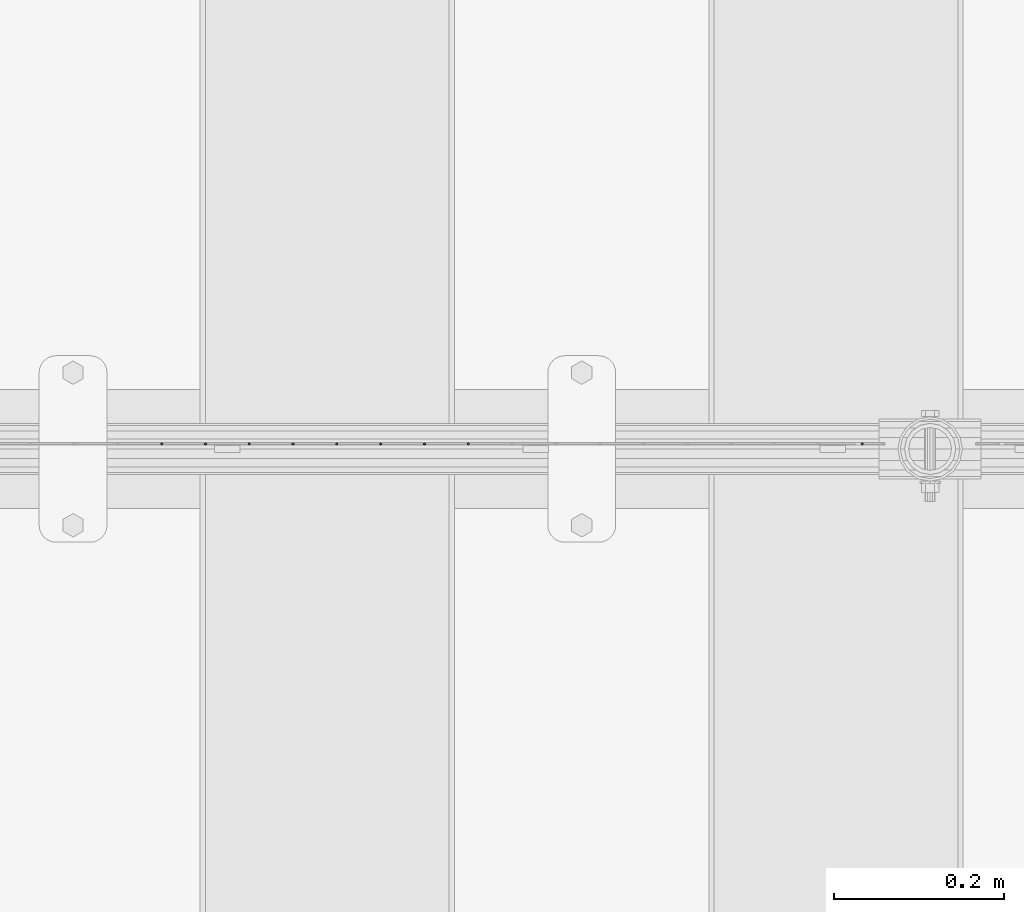
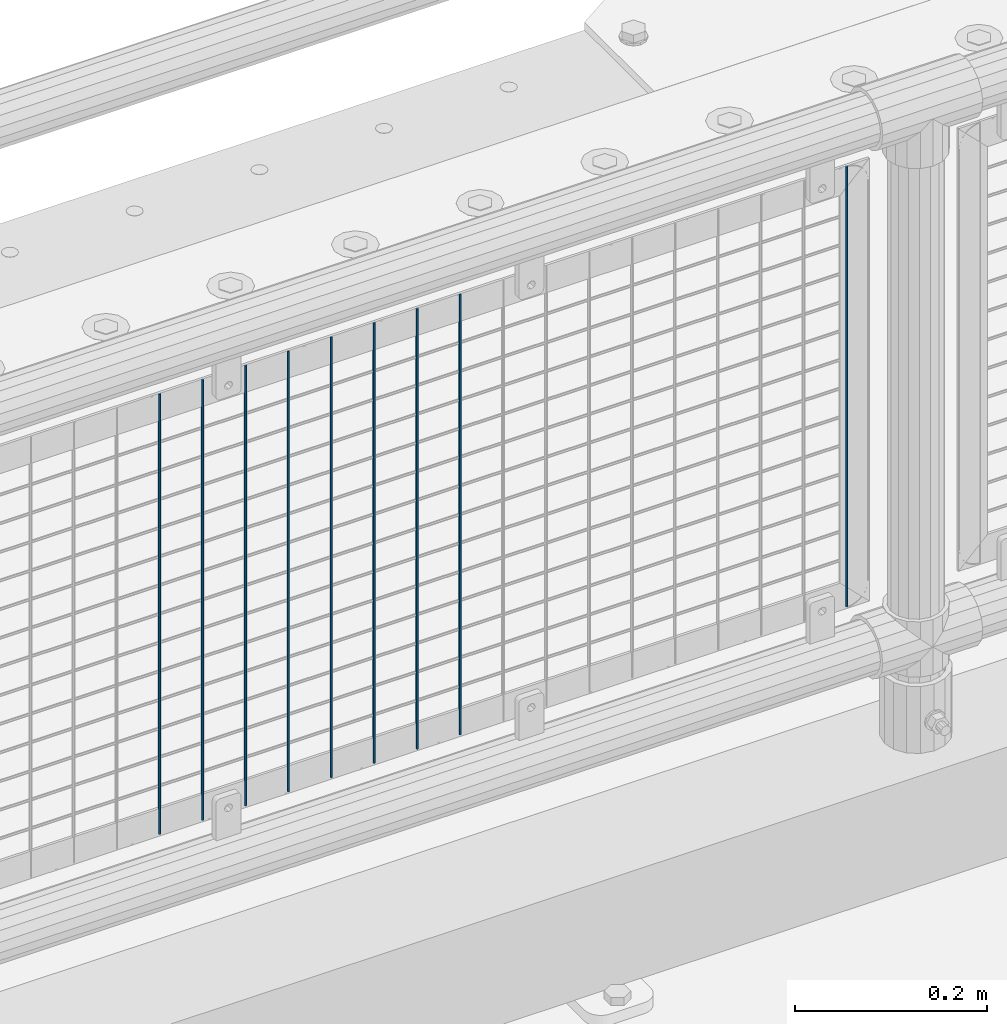
# One storey, part 82 of 219: 9 columns.
"""IFC2X3 building model written with IfcOpenShell, lengths in millimetres."""

import ifcopenshell
import ifcopenshell.guid

model = None  # the IFC model being written
_history = None  # IfcOwnerHistory: only IFC2X3 demands one
_inside = {}  # id of a spatial element -> (the spatial element, [elements in it])
_under = {}  # id of a project, library or spatial element -> (it, [spatial elements below it])
_declared = {}  # id of a project -> (the project, [libraries it declares])
_typed = {}  # id of a type object -> (the type object, [elements of that type])
_made_of = {}  # id of a material, layer set ... -> (it, [elements and type objects made of it])


def new_model(schema):
    """Start an empty IFC model of exactly this schema.

    Asked for "IFC4X3", IfcOpenShell would pick the latest addendum, in which some entities
    have other attributes; the version numbers below select the first issue.
    IFC2X3 requires an IfcOwnerHistory on every rooted entity: one is made here for all.
    """
    global model, _history
    if schema == "IFC4X3":
        model = ifcopenshell.file(schema_version=(4, 3, 0, 0))
    else:
        model = ifcopenshell.file(schema=schema)
    _inside.clear()
    _under.clear()
    _declared.clear()
    _typed.clear()
    _made_of.clear()
    _history = None
    if model.schema == "IFC2X3":
        org = make("IfcOrganization", Name="unknown")
        user = make(
            "IfcPersonAndOrganization",
            ThePerson=make("IfcPerson", FamilyName="unknown"),
            TheOrganization=org,
        )
        app = make(
            "IfcApplication",
            ApplicationDeveloper=org,
            Version="unknown",
            ApplicationFullName="unknown",
            ApplicationIdentifier="unknown",
        )
        _history = make(
            "IfcOwnerHistory",
            OwningUser=user,
            OwningApplication=app,
            ChangeAction="ADDED",
            CreationDate=0,
        )
    return model


def make(cls, **values):
    """One entity of the class cls with the attributes given. An attribute that is None is left unset."""
    return model.create_entity(
        cls, **{name: value for name, value in values.items() if value is not None}
    )


def rooted(cls, **values):
    """An entity with a GlobalId (a new one), such as an element, a storey or a relation."""
    return make(cls, GlobalId=ifcopenshell.guid.new(), OwnerHistory=_history, **values)


def si_unit(unit_type, name, prefix=None):
    """IfcSIUnit, for example si_unit("LENGTHUNIT", "METRE", prefix="MILLI")."""
    return make("IfcSIUnit", UnitType=unit_type, Prefix=prefix, Name=name)


def assignment(units):
    """IfcUnitAssignment: the units of a project."""
    return None if units is None else make("IfcUnitAssignment", Units=units)


def point(xyz):
    """IfcCartesianPoint."""
    return None if xyz is None else make("IfcCartesianPoint", Coordinates=xyz)


def direction(xyz):
    """IfcDirection."""
    return None if xyz is None else make("IfcDirection", DirectionRatios=xyz)


def frame(location, z_axis=None, x_axis=None):
    """IfcAxis2Placement3D, a coordinate frame: its origin and axes. An axis left out is left unset."""
    return make(
        "IfcAxis2Placement3D",
        Location=point(location),
        Axis=direction(z_axis),
        RefDirection=direction(x_axis),
    )


def origin_with_axes():
    """The frame at (0, 0, 0) with the z axis (0, 0, 1) and the x axis (1, 0, 0) written out."""
    return frame((0.0, 0.0, 0.0), z_axis=(0.0, 0.0, 1.0), x_axis=(1.0, 0.0, 0.0))


def place(relative_to, where):
    """IfcLocalPlacement: puts the frame where relative to a parent placement (None: the world)."""
    return make(
        "IfcLocalPlacement", PlacementRelTo=relative_to, RelativePlacement=where
    )


def context(
    kind, dimensions, precision=None, world=None, true_north=None, identifier=None
):
    """IfcGeometricRepresentationContext, for example the 3D "Model" context."""
    return make(
        "IfcGeometricRepresentationContext",
        ContextIdentifier=identifier,
        ContextType=kind,
        CoordinateSpaceDimension=dimensions,
        Precision=precision,
        WorldCoordinateSystem=world,
        TrueNorth=true_north,
    )


def subcontext(parent, identifier, kind, view, scale=None):
    """IfcGeometricRepresentationSubContext, for example "Body" below "Model"."""
    return make(
        "IfcGeometricRepresentationSubContext",
        ContextIdentifier=identifier,
        ContextType=kind,
        ParentContext=parent,
        TargetScale=scale,
        TargetView=view,
    )


def project(units=None, contexts=None):
    """IfcProject with its units and contexts."""
    return rooted(
        "IfcProject",
        Name="project",
        RepresentationContexts=contexts,
        UnitsInContext=assignment(units),
    )


def spatial(cls, under=None, at=None, **own):
    """A site, building, storey or space (cls), placed at a placement, below another one or the project."""
    s = rooted(cls, ObjectPlacement=at, **own)
    if under is not None:
        _under.setdefault(under.id(), (under, []))[1].append(s)
    return s


def faces_of(points, faces, orient=None, outer=None):
    """IfcFace entities. A face is a list of loops; a loop is a list of indices into points, from 0.

    orient and outer hold one flag for each loop. By default every Orientation is true, the
    first loop of a face is its IfcFaceOuterBound and the others are IfcFaceBound.
    """
    made = []
    for i, loops in enumerate(faces):
        bounds = []
        for j, loop in enumerate(loops):
            is_outer = j == 0 if outer is None else outer[i][j]
            bounds.append(
                make(
                    "IfcFaceOuterBound" if is_outer else "IfcFaceBound",
                    Bound=make("IfcPolyLoop", Polygon=[points[k] for k in loop]),
                    Orientation=True if orient is None else orient[i][j],
                )
            )
        made.append(make("IfcFace", Bounds=bounds))
    return made


def faceted_brep(points, faces, orient=None, outer=None, voids=None):
    """IfcFacetedBrep: a solid bounded by flat faces; with voids (closed shells), ...WithVoids."""
    shared = [point(p) for p in points]
    hull = make("IfcClosedShell", CfsFaces=faces_of(shared, faces, orient, outer))
    if voids is None:
        return make("IfcFacetedBrep", Outer=hull)
    return make(
        "IfcFacetedBrepWithVoids",
        Outer=hull,
        Voids=[
            make(cls, CfsFaces=faces_of(shared, fs, o, b)) for cls, fs, o, b in voids
        ],
    )


def shape(context_of_items, identifier, shape_type, items):
    """IfcShapeRepresentation: the items that make up one representation, for example the "Body"."""
    return make(
        "IfcShapeRepresentation",
        ContextOfItems=context_of_items,
        RepresentationIdentifier=identifier,
        RepresentationType=shape_type,
        Items=items,
    )


def material(Name=None, Category=None):
    """IfcMaterial."""
    return make("IfcMaterial", Name=Name, Category=Category)


def made_of(thing, what):
    """Note that an element or type object is made of a material, layer set ...; save() writes the relation."""
    if what is not None:
        _made_of.setdefault(what.id(), (what, []))[1].append(thing)
    return thing


def type_object(cls, material=None, **own):
    """A type object (cls), such as IfcWallType, which elements share."""
    return made_of(rooted(cls, **own), material)


def element(
    cls,
    number,
    at=None,
    inside=None,
    cuts=None,
    type_object=None,
    material=None,
    context=None,
    identifier="Body",
    shape_type=None,
    held_by="IfcProductDefinitionShape",
    body=None,
    shapes=None,
    **own,
):
    """One element of the class cls, such as IfcWall. Its Tag is "e" and its number.

    at: its placement. inside: the storey or other place that contains it. cuts: it is an
    opening in that element (IfcRelVoidsElement). A single representation is given by context,
    identifier, shape_type and body (its items); several are given by shapes. held_by: the class
    of the entity that holds the representations. save() writes the other relations.
    """
    e = rooted(cls, Tag="e%d" % number, ObjectPlacement=at, **own)
    if body is not None:
        shapes = [shape(context, identifier, shape_type, body)]
    if shapes is not None:
        e.Representation = make(held_by, Representations=shapes)
    if inside is not None:
        _inside.setdefault(inside.id(), (inside, []))[1].append(e)
    if cuts is not None:
        rooted(
            "IfcRelVoidsElement", RelatingBuildingElement=cuts, RelatedOpeningElement=e
        )
    if type_object is not None:
        _typed.setdefault(type_object.id(), (type_object, []))[1].append(e)
    return made_of(e, material)


def aggregate(whole, parts):
    """IfcRelAggregates: a whole, such as a stair, and the parts it consists of."""
    return rooted("IfcRelAggregates", RelatingObject=whole, RelatedObjects=parts)


def save(model, path):
    """Write the relations noted so far, then the file.

    IfcRelAggregates (storeys below a building ...), IfcRelContainedInSpatialStructure (elements
    in a storey), IfcRelDefinesByType, IfcRelAssociatesMaterial and IfcRelDeclares: one each for
    every whole, place, type object, material and project.
    """
    for whole, parts in _under.values():
        aggregate(whole, parts)
    for where, things in _inside.values():
        rooted(
            "IfcRelContainedInSpatialStructure",
            RelatedElements=things,
            RelatingStructure=where,
        )
    for kind, things in _typed.values():
        rooted("IfcRelDefinesByType", RelatedObjects=things, RelatingType=kind)
    for what, things in _made_of.values():
        rooted("IfcRelAssociatesMaterial", RelatedObjects=things, RelatingMaterial=what)
    for by, libraries in _declared.values():
        rooted("IfcRelDeclares", RelatingContext=by, RelatedDefinitions=libraries)
    model.write(path)


model = new_model("IFC2X3")

# Units and contexts
model_context = context("Model", 3, precision=1e-05, world=origin_with_axes())
body_context = subcontext(model_context, "Body", "Model", "MODEL_VIEW")
ifc_project = project(units=[si_unit("LENGTHUNIT", "METRE", prefix="MILLI"), si_unit("AREAUNIT", "SQUARE_METRE"), si_unit("VOLUMEUNIT", "CUBIC_METRE"), si_unit("MASSUNIT", "GRAM", prefix="KILO"), si_unit("TIMEUNIT", "SECOND"), si_unit("PLANEANGLEUNIT", "RADIAN"), si_unit("SOLIDANGLEUNIT", "STERADIAN"), si_unit("THERMODYNAMICTEMPERATUREUNIT", "DEGREE_CELSIUS"), si_unit("LUMINOUSINTENSITYUNIT", "LUMEN")], contexts=[model_context])

# Site, building, storey
site_placement = place(None, origin_with_axes())
site = spatial("IfcSite", under=ifc_project, at=site_placement, CompositionType="ELEMENT")
building_placement = place(site_placement, origin_with_axes())
building = spatial("IfcBuilding", under=site, at=building_placement, Name="Standard", CompositionType="ELEMENT")
storey_placement = place(building_placement, origin_with_axes())
storey = spatial("IfcBuildingStorey", under=building, at=storey_placement, Name="Undefined", CompositionType="ELEMENT", Elevation=0.0)

# Columns
ifc_material = material(Name="Misc_Undefined")
column_type = type_object("IfcColumnType", Name="D3", PredefinedType="NOTDEFINED")
for number, where, z_axis, x_axis in (
    (1, (8366.1, 31670.5, 353.020000000001), (-1.0, 0.0, 0.0), (0.0, 0.0, 1.0)),
    (2, (8314.445, 31670.5, 353.020000000001), (-1.0, 0.0, 0.0), (0.0, 0.0, 1.0)),
    (3, (8262.79, 31670.5, 353.020000000001), (-1.0, 0.0, 0.0), (0.0, 0.0, 1.0)),
    (4, (8211.135, 31670.5, 353.020000000001), (-1.0, 0.0, 0.0), (0.0, 0.0, 1.0)),
    (5, (8159.48, 31670.5, 353.020000000001), (-1.0, 0.0, 0.0), (0.0, 0.0, 1.0)),
    (6, (8107.825, 31670.5, 353.020000000001), (-1.0, 0.0, 0.0), (0.0, 0.0, 1.0)),
    (7, (8056.17, 31670.5, 353.020000000001), (-1.0, 0.0, 0.0), (0.0, 0.0, 1.0)),
    (8, (8004.515, 31670.5, 353.020000000001), (-1.0, 0.0, 0.0), (0.0, 0.0, 1.0)),
    (9, (8830.995, 31670.5, 353.020000000001), (-1.0, 0.0, 0.0), (0.0, 0.0, 1.0)),
):
    element("IfcColumn", number, at=place(storey_placement, frame(where, z_axis=z_axis, x_axis=x_axis)), inside=storey, type_object=column_type, material=ifc_material, ObjectType="D3", context=body_context, shape_type="Brep", body=[
        faceted_brep([(0.0, -1.5, -5.6843418860808e-14), (0.0, -0.75, -1.29903810567669), (560.0, -0.75, -1.29903810567703), (560.0, -1.5, 0.0), (0.0, 0.75, -1.29903810567669), (560.0, 0.75, -1.29903810567703), (0.0, 1.5, -5.6843418860808e-14), (560.0, 1.5, 0.0), (0.0, 0.75, 1.29903810567669), (560.0, 0.75, 1.29903810567703), (0.0, -0.75, 1.29903810567669), (560.0, -0.75, 1.29903810567703)], [[[0, 1, 2, 3]], [[1, 4, 5, 2]], [[4, 6, 7, 5]], [[6, 8, 9, 7]], [[8, 10, 11, 9]], [[10, 0, 3, 11]], [[5, 7, 9, 11, 3, 2]], [[10, 8, 6, 4, 1, 0]]]),
    ])

save(model, "model.ifc")
